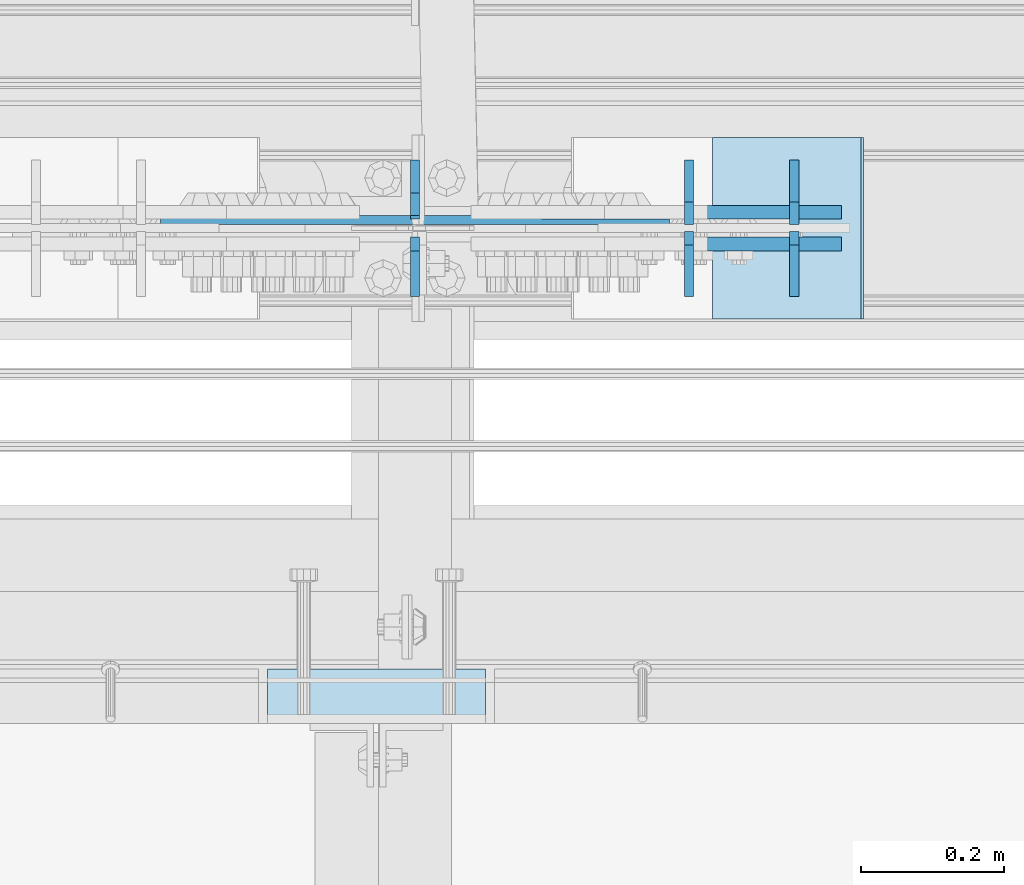
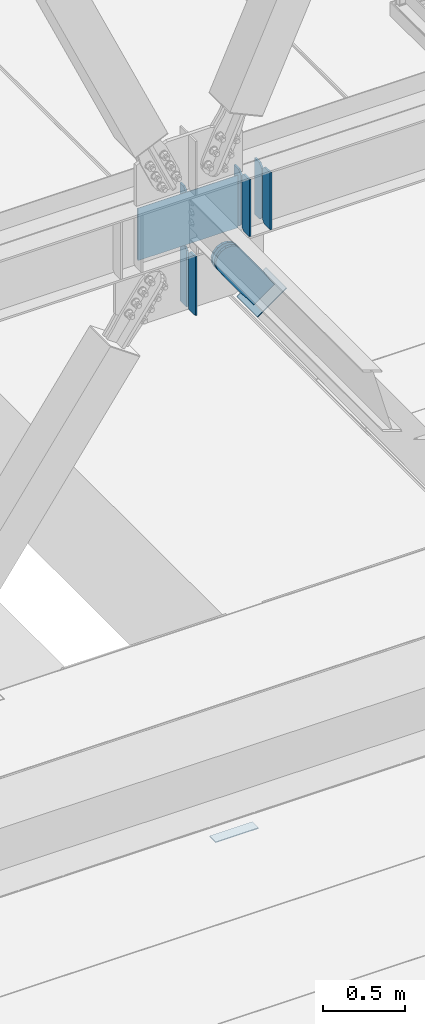
# One storey, part 3129 of 3843: 12 plates, 5 elements without a shape of their own.
"""IFC2X3 building model written with IfcOpenShell, lengths in millimetres."""

from ifc_helpers import new_model, si_unit, frame, origin_with_axes, place, context, subcontext, project, spatial, faceted_brep, material, type_object, element, aggregate, save


model = new_model("IFC2X3")

# Units and contexts
model_context = context("Model", 3, precision=1e-05, world=origin_with_axes())
body_context = subcontext(model_context, "Body", "Model", "MODEL_VIEW")
ifc_project = project(units=[si_unit("LENGTHUNIT", "METRE", prefix="MILLI"), si_unit("AREAUNIT", "SQUARE_METRE"), si_unit("VOLUMEUNIT", "CUBIC_METRE"), si_unit("MASSUNIT", "GRAM", prefix="KILO"), si_unit("TIMEUNIT", "SECOND"), si_unit("PLANEANGLEUNIT", "RADIAN"), si_unit("SOLIDANGLEUNIT", "STERADIAN"), si_unit("THERMODYNAMICTEMPERATUREUNIT", "DEGREE_CELSIUS"), si_unit("LUMINOUSINTENSITYUNIT", "LUMEN")], contexts=[model_context])

# Site, building, storey
site_placement = place(None, origin_with_axes())
site = spatial("IfcSite", under=ifc_project, at=site_placement, CompositionType="ELEMENT")
building_placement = place(site_placement, origin_with_axes())
building = spatial("IfcBuilding", under=site, at=building_placement, Name="Undefined", CompositionType="ELEMENT")
storey_placement = place(building_placement, origin_with_axes())
storey = spatial("IfcBuildingStorey", under=building, at=storey_placement, Name="Undefined", CompositionType="ELEMENT", Elevation=0.0)

# Assembly, plate
assembly_1_placement = place(storey_placement, origin_with_axes())
assembly_1 = element("IfcElementAssembly", 1, at=assembly_1_placement, inside=storey, Name="EMBED PLATE", AssemblyPlace="NOTDEFINED", PredefinedType="RIGID_FRAME")
ifc_material_1 = material(Name="STEEL/A36")
plate_type_1 = type_object("IfcPlateType", PredefinedType="NOTDEFINED")
plate_1_placement = place(assembly_1_placement, frame((45627.925, 24923.75, 30400.625), z_axis=(-1.0, 0.0, 0.0), x_axis=(0.0, 1.0, 0.0)))
plate_1 = element("IfcPlate", 2, at=plate_1_placement, type_object=plate_type_1, material=ifc_material_1, Name="PLATE", context=body_context, shape_type="Brep", body=[
    faceted_brep([(0.0, -3.17499999999927, 0.0), (0.0, -3.17499999999927, 304.800000000003), (0.0, 3.17499999999927, 304.800000000003), (0.0, 3.17499999999927, 0.0), (76.1999999999971, -3.17499999999927, 304.799999999996), (76.1999999999971, 3.17499999999927, 304.799999999996), (76.1999999999971, -3.17499999999927, 0.0), (76.1999999999971, 3.17499999999927, 0.0)], [[[0, 1, 2, 3]], [[1, 4, 5, 2]], [[4, 6, 7, 5]], [[6, 0, 3, 7]], [[5, 7, 3, 2]], [[6, 4, 1, 0]]]),
])
aggregate(assembly_1, [plate_1])

# Assembly, plates
assembly_2_placement = place(storey_placement, origin_with_axes())
assembly_2 = element("IfcElementAssembly", 3, at=assembly_2_placement, inside=storey, Name="BEAM", AssemblyPlace="NOTDEFINED", PredefinedType="RIGID_FRAME")
ifc_material_2 = material(Name="STEEL/A572-50")
plate_type_2 = type_object("IfcPlateType", PredefinedType="NOTDEFINED")
plate_2_placement = place(assembly_2_placement, frame((45912.2854380837, 25620.6625, 34369.375), z_axis=(0.0, 0.0, 1.0), x_axis=(0.0, 1.0, 0.0)))
plate_2 = element("IfcPlate", 4, at=plate_2_placement, type_object=plate_type_2, material=ifc_material_2, Name="PLATE", context=body_context, shape_type="Brep", body=[
    faceted_brep([(0.0, -6.35000000000582, 31.75), (0.0, -6.34999999999854, 393.700012207031), (0.0, 6.34999999999854, 393.700012207031), (0.0, 6.35000000000582, 31.75), (31.75, -6.34999999999854, 425.450012207031), (31.75, 6.34999999999854, 425.450012207031), (90.4875030517578, -6.34999999999854, 425.450012207031), (90.4875030517578, 6.34999999999854, 425.450012207031), (90.4875030517578, -6.34999999999854, 0.0), (90.4875030517578, 6.34999999999854, 0.0), (31.75, -6.35000000000582, 0.0), (31.75, 6.35000000000582, 0.0)], [[[0, 1, 2, 3]], [[1, 4, 5, 2]], [[4, 6, 7, 5]], [[6, 8, 9, 7]], [[8, 10, 11, 9]], [[10, 0, 3, 11]], [[5, 7, 9, 11, 3, 2]], [[10, 8, 6, 4, 1, 0]]]),
])
plate_3_placement = place(assembly_2_placement, frame((45912.2854380839, 25611.1375, 34369.375), z_axis=(0.0, 0.0, 1.0), x_axis=(0.0, -1.0, 0.0)))
plate_3 = element("IfcPlate", 5, at=plate_3_placement, type_object=plate_type_2, material=ifc_material_2, Name="PLATE", context=body_context, shape_type="Brep", body=[
    faceted_brep([(0.0, -6.34999999999854, 19.0499992370605), (0.0, -6.34999999999854, 407.987506866455), (0.0, 6.34999999999854, 407.987506866455), (0.0, 6.34999999999854, 19.0499992370605), (19.0499992370605, -6.34999999999854, 427.037506103516), (19.0499992370605, 6.34999999999854, 427.037506103516), (90.4874984741218, -6.34999999999854, 427.037506103516), (90.4874984741218, 6.34999999999854, 427.037506103516), (90.4875030517578, -6.34999999999854, 0.0), (90.4875030517578, 6.34999999999854, 0.0), (19.0499992370605, -6.34999999999854, 0.0), (19.0499992370605, 6.34999999999854, 0.0)], [[[0, 1, 2, 3]], [[1, 4, 5, 2]], [[4, 6, 7, 5]], [[6, 8, 9, 7]], [[8, 10, 11, 9]], [[10, 0, 3, 11]], [[5, 7, 9, 11, 3, 2]], [[10, 8, 6, 4, 1, 0]]]),
])
plate_4_placement = place(assembly_2_placement, frame((46059.3276250837, 25620.6625, 34369.375), z_axis=(0.0, 0.0, 1.0), x_axis=(0.0, 1.0, 0.0)))
plate_4 = element("IfcPlate", 6, at=plate_4_placement, type_object=plate_type_2, material=ifc_material_2, Name="PLATE", context=body_context, shape_type="Brep", body=[
    faceted_brep([(0.0, -6.35000000000582, 31.75), (0.0, -6.34999999999854, 393.700012207031), (0.0, 6.34999999999854, 393.700012207031), (0.0, 6.35000000000582, 31.75), (31.75, -6.34999999999854, 425.450012207031), (31.75, 6.34999999999854, 425.450012207031), (90.4875030517578, -6.34999999999854, 425.450012207031), (90.4875030517578, 6.34999999999854, 425.450012207031), (90.4875030517578, -6.34999999999854, 0.0), (90.4875030517578, 6.34999999999854, 0.0), (31.75, -6.35000000000582, 0.0), (31.75, 6.35000000000582, 0.0)], [[[0, 1, 2, 3]], [[1, 4, 5, 2]], [[4, 6, 7, 5]], [[6, 8, 9, 7]], [[8, 10, 11, 9]], [[10, 0, 3, 11]], [[5, 7, 9, 11, 3, 2]], [[10, 8, 6, 4, 1, 0]]]),
])
plate_5_placement = place(assembly_2_placement, frame((46059.3276250839, 25611.1375, 34369.375), z_axis=(0.0, 0.0, 1.0), x_axis=(0.0, -1.0, 0.0)))
plate_5 = element("IfcPlate", 7, at=plate_5_placement, type_object=plate_type_2, material=ifc_material_2, Name="PLATE", context=body_context, shape_type="Brep", body=[
    faceted_brep([(0.0, -6.34999999999854, 19.0499992370605), (0.0, -6.34999999999854, 407.987506866455), (0.0, 6.34999999999854, 407.987506866455), (0.0, 6.34999999999854, 19.0499992370605), (19.0499992370605, -6.34999999999854, 427.037506103516), (19.0499992370605, 6.34999999999854, 427.037506103516), (90.4874984741218, -6.34999999999854, 427.037506103516), (90.4874984741218, 6.34999999999854, 427.037506103516), (90.4875030517578, -6.34999999999854, 0.0), (90.4875030517578, 6.34999999999854, 0.0), (19.0499992370605, -6.34999999999854, 0.0), (19.0499992370605, 6.34999999999854, 0.0)], [[[0, 1, 2, 3]], [[1, 4, 5, 2]], [[4, 6, 7, 5]], [[6, 8, 9, 7]], [[8, 10, 11, 9]], [[10, 0, 3, 11]], [[5, 7, 9, 11, 3, 2]], [[10, 8, 6, 4, 1, 0]]]),
])
plate_type_3 = type_object("IfcPlateType", PredefinedType="NOTDEFINED")
plate_6_placement = place(assembly_2_placement, frame((45885.1, 25627.0125, 34385.25), z_axis=(0.0, 0.0, 1.0), x_axis=(-1.0, 0.0, 0.0)))
plate_6 = element("IfcPlate", 8, at=plate_6_placement, type_object=plate_type_3, material=ifc_material_2, Name="PLATE", context=body_context, shape_type="Brep", body=[
    faceted_brep([(7.27595761418343e-12, 6.3499999046162, 0.0), (711.199999999997, 6.34999999999854, 0.0), (711.199999999997, -6.34999999999854, 7.33234841687954), (0.0, -6.34999999999854, 7.33234841687954), (711.200000000012, 6.34999999999854, 393.700000000004), (711.200000000012, -6.34999999999854, 386.367651583125), (1.45519152283669e-11, -6.34999999999854, 386.367651583125), (0.0, 6.34999999999854, 393.700012207031)], [[[0, 1, 2, 3]], [[2, 1, 4, 5]], [[3, 2, 5, 6]], [[0, 3, 6, 7]], [[1, 0, 7, 4]], [[6, 5, 4, 7]]]),
])
plate_type_4 = type_object("IfcPlateType", PredefinedType="NOTDEFINED")
plate_7_placement = place(assembly_2_placement, frame((45529.5004999163, 25633.3625, 34369.375), z_axis=(0.0, 0.0, 1.0), x_axis=(0.0, 1.0, 0.0)))
plate_7 = element("IfcPlate", 9, at=plate_7_placement, type_object=plate_type_4, material=ifc_material_2, Name="PLATE", context=body_context, shape_type="Brep", body=[
    faceted_brep([(0.0, -6.35000000000582, 31.75), (0.0, -6.34999999999854, 393.700012207031), (0.0, 6.34999999999854, 393.700012207031), (0.0, 6.35000000000582, 31.75), (31.75, -6.34999999999854, 425.450012207031), (31.75, 6.34999999999854, 425.450012207031), (77.7875030517571, -6.34999999999854, 425.450012207031), (77.7875030517571, 6.34999999999854, 425.450012207031), (77.7875030517571, -6.34999999999854, 0.0), (77.7875030517571, 6.34999999999854, 0.0), (31.75, -6.35000000000582, 0.0), (31.75, 6.35000000000582, 0.0)], [[[0, 1, 2, 3]], [[1, 4, 5, 2]], [[4, 6, 7, 5]], [[6, 8, 9, 7]], [[8, 10, 11, 9]], [[10, 0, 3, 11]], [[5, 7, 9, 11, 3, 2]], [[10, 8, 6, 4, 1, 0]]]),
])

# Assembly, plate
assembly_3_placement = place(storey_placement, origin_with_axes())
assembly_3 = element("IfcElementAssembly", 10, at=assembly_3_placement, inside=storey, AssemblyPlace="NOTDEFINED", PredefinedType="RIGID_FRAME")
plate_type_5 = type_object("IfcPlateType", PredefinedType="NOTDEFINED")
plate_8_placement = place(assembly_3_placement, frame((46085.2577554586, 25638.125, 33951.8646801672), z_axis=(-0.816439959974282, 0.0, -0.5774303349818), x_axis=(0.577430334981802, 0.0, -0.81643995997428)))
plate_8 = element("IfcPlate", 11, at=plate_8_placement, type_object=plate_type_5, material=ifc_material_1, context=body_context, shape_type="Brep", body=[
    faceted_brep([(0.0, -9.52500000000146, 0.0), (-101.59999999866, -9.52499999999418, -7.01164927375794), (-101.59999999866, 9.52499999999418, -7.01164927375794), (0.0, 9.52500000000146, 0.0), (-364.729297655074, -9.52499999999418, -7.01164927444188), (-364.729297655074, 9.52499999999418, -7.01164927444188), (-401.787405121293, -9.52499999999418, 0.359666612348519), (-401.787405121293, 9.52499999999418, 0.359666612348519), (-433.203751657995, -9.52499999999418, 21.3513982502482), (-433.203751657995, 9.52499999999418, 21.3513982502482), (-454.195483294687, -9.52499999999418, 52.7677447877504), (-454.195483294687, 9.52499999999418, 52.7677447877504), (-461.566799180051, -9.52499999999418, 89.8258492000314), (-461.566799180051, 9.52499999999418, 89.8258492000314), (-454.195483292249, -9.52499999999418, 126.883956664562), (-454.195483292249, 9.52499999999418, 126.883956664562), (-433.203751654662, -9.52499999999418, 158.300303199998), (-433.203751654662, 9.52499999999418, 158.300303199998), (-401.787405118426, -9.52499999999418, 179.292034836384), (-401.787405118426, 9.52499999999418, 179.292034836384), (-364.729299177612, -9.52499999999418, 186.663350722738), (-364.729299177612, 9.52499999999418, 186.663350722738), (-101.5999999907, -9.52499999999418, 186.663350723451), (-101.5999999907, 9.52499999999418, 186.663350723451), (7.37782102078199e-09, -9.52499999999418, 179.651701450231), (7.37782102078199e-09, 9.52499999999418, 179.651701450231), (69.8500000062704, -9.52499999999418, 179.651701450392), (69.8500000062704, 9.52499999999418, 179.651701450392), (69.8499999979995, -9.52499999999418, -4.00177668780088e-10), (69.8499999979995, 9.52499999999418, -4.00177668780088e-10)], [[[0, 1, 2, 3]], [[1, 4, 5, 2]], [[4, 6, 7, 5]], [[6, 8, 9, 7]], [[8, 10, 11, 9]], [[10, 12, 13, 11]], [[12, 14, 15, 13]], [[14, 16, 17, 15]], [[16, 18, 19, 17]], [[18, 20, 21, 19]], [[20, 22, 23, 21]], [[22, 24, 25, 23]], [[24, 26, 27, 25]], [[26, 28, 29, 27]], [[28, 0, 3, 29]], [[5, 7, 9, 11, 13, 15, 17, 19, 21, 23, 25, 27, 29, 3, 2]], [[28, 26, 24, 22, 20, 18, 16, 14, 12, 10, 8, 6, 4, 1, 0]]]),
])
aggregate(assembly_3, [plate_8])

assembly_4_placement = place(storey_placement, origin_with_axes())
assembly_4 = element("IfcElementAssembly", 12, at=assembly_4_placement, inside=storey, AssemblyPlace="NOTDEFINED", PredefinedType="RIGID_FRAME")
plate_9_placement = place(assembly_4_placement, frame((46085.2577554586, 25593.675, 33951.8646801672), z_axis=(-0.816439959974282, 0.0, -0.5774303349818), x_axis=(0.577430334981802, 0.0, -0.81643995997428)))
plate_9 = element("IfcPlate", 13, at=plate_9_placement, type_object=plate_type_5, material=ifc_material_1, context=body_context, shape_type="Brep", body=[
    faceted_brep([(0.0, -9.52500000000146, 0.0), (-101.59999999866, -9.52499999999418, -7.01164927375794), (-101.59999999866, 9.52499999999418, -7.01164927375794), (0.0, 9.52500000000146, 0.0), (-364.729297655074, -9.52499999999418, -7.01164927444188), (-364.729297655074, 9.52499999999418, -7.01164927444188), (-401.787405121293, -9.52499999999418, 0.359666612348519), (-401.787405121293, 9.52499999999418, 0.359666612348519), (-433.203751657995, -9.52499999999418, 21.3513982502482), (-433.203751657995, 9.52499999999418, 21.3513982502482), (-454.195483294687, -9.52499999999418, 52.7677447877504), (-454.195483294687, 9.52499999999418, 52.7677447877504), (-461.566799180051, -9.52499999999418, 89.8258492000314), (-461.566799180051, 9.52499999999418, 89.8258492000314), (-454.195483292249, -9.52499999999418, 126.883956664562), (-454.195483292249, 9.52499999999418, 126.883956664562), (-433.203751654662, -9.52499999999418, 158.300303199998), (-433.203751654662, 9.52499999999418, 158.300303199998), (-401.787405118426, -9.52499999999418, 179.292034836384), (-401.787405118426, 9.52499999999418, 179.292034836384), (-364.729299177612, -9.52499999999418, 186.663350722738), (-364.729299177612, 9.52499999999418, 186.663350722738), (-101.5999999907, -9.52499999999418, 186.663350723451), (-101.5999999907, 9.52499999999418, 186.663350723451), (7.37782102078199e-09, -9.52499999999418, 179.651701450231), (7.37782102078199e-09, 9.52499999999418, 179.651701450231), (69.8500000062704, -9.52499999999418, 179.651701450392), (69.8500000062704, 9.52499999999418, 179.651701450392), (69.8499999979995, -9.52499999999418, -4.00177668780088e-10), (69.8499999979995, 9.52499999999418, -4.00177668780088e-10)], [[[0, 1, 2, 3]], [[1, 4, 5, 2]], [[4, 6, 7, 5]], [[6, 8, 9, 7]], [[8, 10, 11, 9]], [[10, 12, 13, 11]], [[12, 14, 15, 13]], [[14, 16, 17, 15]], [[16, 18, 19, 17]], [[18, 20, 21, 19]], [[20, 22, 23, 21]], [[22, 24, 25, 23]], [[24, 26, 27, 25]], [[26, 28, 29, 27]], [[28, 0, 3, 29]], [[5, 7, 9, 11, 13, 15, 17, 19, 21, 23, 25, 27, 29, 3, 2]], [[28, 26, 24, 22, 20, 18, 16, 14, 12, 10, 8, 6, 4, 1, 0]]]),
])
aggregate(assembly_4, [plate_9])

assembly_5_placement = place(storey_placement, origin_with_axes())
assembly_5 = element("IfcElementAssembly", 14, at=assembly_5_placement, inside=storey, Name="Plate", AssemblyPlace="NOTDEFINED", PredefinedType="RIGID_FRAME")
plate_type_6 = type_object("IfcPlateType", PredefinedType="NOTDEFINED")
plate_10_placement = place(assembly_5_placement, frame((45946.7326346127, 25742.9, 33772.2267225417), z_axis=(0.816439959974278, 0.0, 0.577430334981805), x_axis=(0.0, -1.0, 0.0)))
plate_10 = element("IfcPlate", 15, at=plate_10_placement, type_object=plate_type_6, material=ifc_material_1, Name="Plate", context=body_context, shape_type="Brep", body=[
    faceted_brep([(0.0, -3.17499999999927, 0.0), (0.0, -3.17499999965185, 254.000000005151), (0.0, 3.17500000035216, 254.000000005166), (0.0, 3.17499999999927, 0.0), (254.0, -3.17499999965185, 254.000000005151), (254.0, 3.17500000035216, 254.000000005166), (254.0, -3.17500000000291, 0.0), (254.0, 3.17499999999927, 1.45519152283669e-11)], [[[0, 1, 2, 3]], [[1, 4, 5, 2]], [[4, 6, 7, 5]], [[6, 0, 3, 7]], [[5, 7, 3, 2]], [[6, 4, 1, 0]]]),
])
aggregate(assembly_5, [plate_10])

# Plate
plate_type_7 = type_object("IfcPlateType", PredefinedType="NOTDEFINED")
plate_11_placement = place(assembly_2_placement, frame((45529.5, 25628.6, 33912.373438), z_axis=(0.0, 1.0, 0.0), x_axis=(0.0, 0.0, 1.0)))
plate_11 = element("IfcPlate", 16, at=plate_11_placement, type_object=plate_type_7, material=ifc_material_2, Name="CB", context=body_context, shape_type="Brep", body=[
    faceted_brep([(0.0, -6.3499999046162, 0.0), (0.0, -6.34999999999854, 82.5499999999993), (0.0, 6.34999999999854, 82.5499999999993), (7.27595761418343e-12, 6.3499999046162, 0.0), (441.136831527911, -6.34999999999854, 82.5499999999993), (441.136831527911, 6.34999999999854, 82.5499999999993), (441.136831527911, -6.34999999999854, 19.0499992370605), (441.136831527911, 6.34999999999854, 19.0499992370605), (422.08683229085, -6.34999999999854, 0.0), (422.08683229085, 6.34999999999854, 0.0)], [[[0, 1, 2, 3]], [[1, 4, 5, 2]], [[4, 6, 7, 5]], [[6, 8, 9, 7]], [[8, 0, 3, 9]], [[5, 7, 9, 3, 2]], [[8, 6, 4, 1, 0]]]),
])

plate_12_placement = place(assembly_2_placement, frame((45529.5, 25603.2, 33912.373438), z_axis=(0.0, -1.0, 0.0), x_axis=(0.0, 0.0, 1.0)))
plate_12 = element("IfcPlate", 17, at=plate_12_placement, type_object=plate_type_7, material=ifc_material_2, Name="CB", context=body_context, shape_type="Brep", body=[
    faceted_brep([(0.0, -6.3499999046162, 0.0), (0.0, -6.34999999999854, 82.5499999999993), (0.0, 6.34999999999854, 82.5499999999993), (7.27595761418343e-12, 6.3499999046162, 0.0), (441.136831527911, -6.34999999999854, 82.5499999999993), (441.136831527911, 6.34999999999854, 82.5499999999993), (441.136831527911, -6.34999999999854, 19.0499992370605), (441.136831527911, 6.34999999999854, 19.0499992370605), (422.08683229085, -6.34999999999854, 0.0), (422.08683229085, 6.34999999999854, 0.0)], [[[0, 1, 2, 3]], [[1, 4, 5, 2]], [[4, 6, 7, 5]], [[6, 8, 9, 7]], [[8, 0, 3, 9]], [[5, 7, 9, 3, 2]], [[8, 6, 4, 1, 0]]]),
])

aggregate(assembly_2, [plate_2, plate_3, plate_4, plate_5, plate_7, plate_6, plate_11, plate_12])

save(model, "model.ifc")
